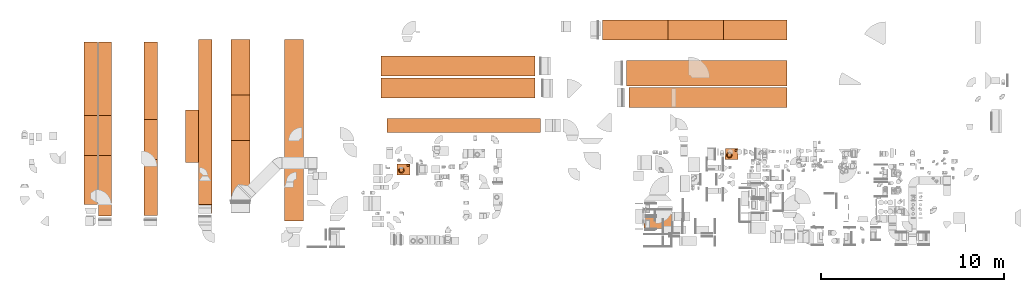
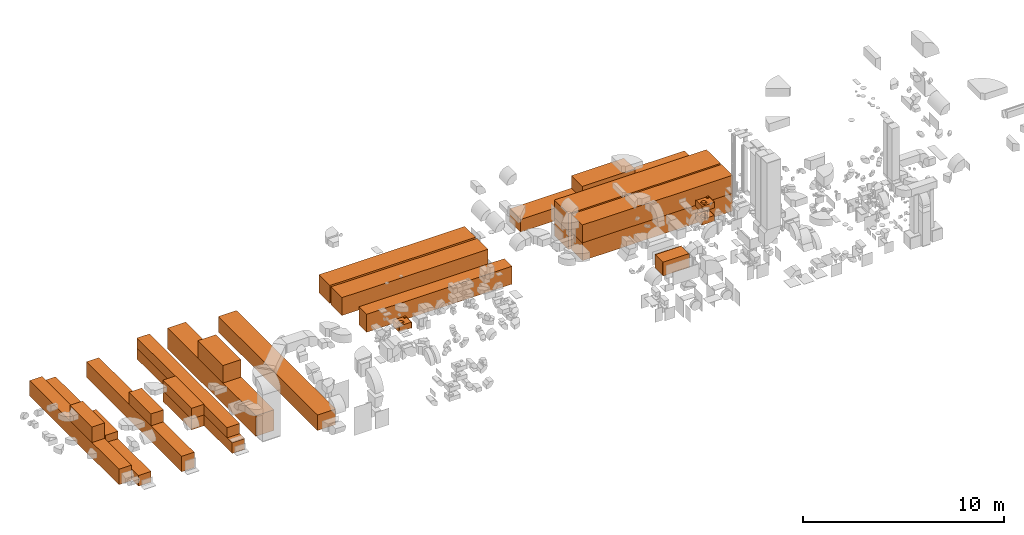
# One storey, part 58 of 59: 26 proxies.
"""IFC2X3 building model written with IfcOpenShell, lengths in millimetres."""

from ifc_helpers import new_model, entity, si_unit, converted_unit, derived_unit, direction, frame, origin, origin_2d_with_axis, place, context, subcontext, project, spatial, rectangle, extrude, faceted_brep, source, transform, mapped, material, material_list, type_object, type_shapes, element, save


model = new_model("IFC2X3")

# Units and contexts
model_context = context("Model", 3, precision=0.01, world=origin(), true_north=direction((6.12303176911189e-17, 1.0)))
body_context = subcontext(model_context, "Body", "Model", "MODEL_VIEW")
ifc_project = project(units=[si_unit("LENGTHUNIT", "METRE", prefix="MILLI"), si_unit("AREAUNIT", "SQUARE_METRE"), si_unit("VOLUMEUNIT", "CUBIC_METRE"), converted_unit("PLANEANGLEUNIT", "DEGREE", entity("IfcRatioMeasure", 0.0174532925199433), si_unit("PLANEANGLEUNIT", "RADIAN"), dimensions=[0, 0, 0, 0, 0, 0, 0]), si_unit("MASSUNIT", "GRAM", prefix="KILO"), derived_unit("MASSDENSITYUNIT", [(si_unit("MASSUNIT", "GRAM", prefix="KILO"), 1), (si_unit("LENGTHUNIT", "METRE"), -3)]), derived_unit("MOMENTOFINERTIAUNIT", [(si_unit("LENGTHUNIT", "METRE"), 4)]), si_unit("TIMEUNIT", "SECOND"), si_unit("FREQUENCYUNIT", "HERTZ"), si_unit("THERMODYNAMICTEMPERATUREUNIT", "DEGREE_CELSIUS"), derived_unit("THERMALTRANSMITTANCEUNIT", [(si_unit("MASSUNIT", "GRAM", prefix="KILO"), 1), (si_unit("THERMODYNAMICTEMPERATUREUNIT", "KELVIN"), -1), (si_unit("TIMEUNIT", "SECOND"), -3)]), derived_unit("VOLUMETRICFLOWRATEUNIT", [(si_unit("LENGTHUNIT", "METRE"), 3), (si_unit("TIMEUNIT", "SECOND"), -1)]), derived_unit("MASSFLOWRATEUNIT", [(si_unit("MASSUNIT", "GRAM", prefix="KILO"), 1), (si_unit("TIMEUNIT", "SECOND"), -1)]), derived_unit("ROTATIONALFREQUENCYUNIT", [(si_unit("TIMEUNIT", "SECOND"), -1)]), si_unit("ELECTRICCURRENTUNIT", "AMPERE"), si_unit("ELECTRICVOLTAGEUNIT", "VOLT"), si_unit("POWERUNIT", "WATT"), si_unit("FORCEUNIT", "NEWTON", prefix="KILO"), si_unit("ILLUMINANCEUNIT", "LUX"), si_unit("LUMINOUSFLUXUNIT", "LUMEN"), si_unit("LUMINOUSINTENSITYUNIT", "CANDELA"), derived_unit("USERDEFINED", [(si_unit("MASSUNIT", "GRAM", prefix="KILO"), -1), (si_unit("LENGTHUNIT", "METRE"), -2), (si_unit("TIMEUNIT", "SECOND"), 3), (si_unit("LUMINOUSFLUXUNIT", "LUMEN"), 1)]), derived_unit("LINEARVELOCITYUNIT", [(si_unit("LENGTHUNIT", "METRE"), 1), (si_unit("TIMEUNIT", "SECOND"), -1)]), si_unit("PRESSUREUNIT", "PASCAL"), derived_unit("USERDEFINED", [(si_unit("LENGTHUNIT", "METRE"), -2), (si_unit("MASSUNIT", "GRAM", prefix="KILO"), 1), (si_unit("TIMEUNIT", "SECOND"), -2)]), derived_unit("LINEARFORCEUNIT", [(si_unit("MASSUNIT", "GRAM", prefix="KILO"), 1), (si_unit("LENGTHUNIT", "METRE"), 1), (si_unit("TIMEUNIT", "SECOND"), -2), (si_unit("LENGTHUNIT", "METRE"), -1)]), derived_unit("PLANARFORCEUNIT", [(si_unit("MASSUNIT", "GRAM", prefix="KILO"), 1), (si_unit("LENGTHUNIT", "METRE"), 1), (si_unit("TIMEUNIT", "SECOND"), -2), (si_unit("LENGTHUNIT", "METRE"), -2)])], contexts=[model_context])

# Site, building, storey
site_placement = place(None, origin())
site = spatial("IfcSite", under=ifc_project, at=site_placement, CompositionType="ELEMENT")
building_placement = place(site_placement, origin())
building = spatial("IfcBuilding", under=site, at=building_placement, CompositionType="ELEMENT")
storey_placement = place(building_placement, frame((0.0, 0.0, 28200.0)))
storey = spatial("IfcBuildingStorey", under=building, at=storey_placement, CompositionType="ELEMENT", Elevation=28200.0)

# Proxies
ifc_material_1 = material()
building_element_proxy_type_1 = type_object("IfcBuildingElementProxyType", PredefinedType="NOTDEFINED", material=ifc_material_1)
shared_shape_1 = source(origin(), body_context, "Body", "SweptSolid", [
    extrude(rectangle(XDim=1090.0, YDim=8400.0, at=origin_2d_with_axis()), origin(), (0.0, 0.0, 1.0), 1090.0),
])
type_shapes(building_element_proxy_type_1, [shared_shape_1])
for number, where, z_axis, x_axis in (
    (1, (32267.57, 16479.61, 1240.0), (0.0, 0.0, 1.0), (1.51880240734974e-07, 1.0, 0.0)),
    (2, (32267.57, 17694.61, 1240.0), (0.0, 0.0, 1.0), (1.51880240734974e-07, 1.0, 0.0)),
):
    element("IfcBuildingElementProxy", number, at=place(storey_placement, frame(where, z_axis=z_axis, x_axis=x_axis)), inside=storey, type_object=building_element_proxy_type_1, material=ifc_material_1, context=body_context, shape_type="MappedRepresentation", body=[
        mapped(shared_shape_1, transform((0.0, 0.0, 0.0), scale=1.0)),
    ])
building_element_proxy_type_2 = type_object("IfcBuildingElementProxyType", PredefinedType="NOTDEFINED", material=ifc_material_1)
shared_shape_2 = source(origin(), body_context, "Body", "SweptSolid", [
    extrude(rectangle(XDim=770.0, YDim=8362.30252754303, at=origin_2d_with_axis()), origin(), (0.0, 0.0, 1.0), 1090.0),
])
type_shapes(building_element_proxy_type_2, [shared_shape_2])
proxy_1_placement = place(storey_placement, frame((32588.88, 14444.61, 1240.0), z_axis=(0.0, 0.0, 1.0), x_axis=(1.51880240734974e-07, 1.0, 0.0)))
element("IfcBuildingElementProxy", 3, at=proxy_1_placement, inside=storey, type_object=building_element_proxy_type_2, material=ifc_material_1, context=body_context, shape_type="MappedRepresentation", body=[
    mapped(shared_shape_2, transform((0.0, 0.0, 0.0), scale=1.0)),
])
building_element_proxy_type_3 = type_object("IfcBuildingElementProxyType", PredefinedType="NOTDEFINED", material=ifc_material_1)
shared_shape_3 = source(origin(), body_context, "Body", "SweptSolid", [
    extrude(rectangle(XDim=724.0, YDim=8898.98200064793, at=origin_2d_with_axis()), origin(), (0.0, 0.0, 1.0), 944.0),
])
type_shapes(building_element_proxy_type_3, [shared_shape_3])
proxy_2_placement = place(storey_placement, frame((12217.8, 14560.11, 150.0)))
element("IfcBuildingElementProxy", 4, at=proxy_2_placement, inside=storey, type_object=building_element_proxy_type_3, material=ifc_material_1, context=body_context, shape_type="MappedRepresentation", body=[
    mapped(shared_shape_3, transform((0.0, 0.0, 0.0), scale=1.0)),
])
building_element_proxy_type_4 = type_object("IfcBuildingElementProxyType", PredefinedType="NOTDEFINED", material=ifc_material_1)
shared_shape_4 = source(origin(), body_context, "Body", "SweptSolid", [
    extrude(rectangle(XDim=719.96467646969, YDim=2845.38357778285, at=origin_2d_with_axis()), origin(), (0.0, 0.0, 1.0), 654.0),
])
type_shapes(building_element_proxy_type_4, [shared_shape_4])
proxy_3_placement = place(storey_placement, frame((17738.36, 13852.3, 804.0)))
element("IfcBuildingElementProxy", 5, at=proxy_3_placement, inside=storey, type_object=building_element_proxy_type_4, material=ifc_material_1, context=body_context, shape_type="MappedRepresentation", body=[
    mapped(shared_shape_4, transform((0.0, 0.0, 0.0), scale=1.0)),
])
building_element_proxy_type_5 = type_object("IfcBuildingElementProxyType", PredefinedType="NOTDEFINED", material=ifc_material_1)
shared_shape_5 = source(origin(), body_context, "Body", "SweptSolid", [
    extrude(rectangle(XDim=723.999999999987, YDim=2845.90572539235, at=origin_2d_with_axis()), origin(), (0.0, 0.0, 1.0), 654.0),
])
type_shapes(building_element_proxy_type_5, [shared_shape_5])
proxy_4_placement = place(storey_placement, frame((17740.38, 13852.56, 150.0)))
element("IfcBuildingElementProxy", 6, at=proxy_4_placement, inside=storey, type_object=building_element_proxy_type_5, material=ifc_material_1, context=body_context, shape_type="MappedRepresentation", body=[
    mapped(shared_shape_5, transform((0.0, 0.0, 0.0), scale=1.0)),
])
building_element_proxy_type_6 = type_object("IfcBuildingElementProxyType", PredefinedType="NOTDEFINED", material=ifc_material_1)
shared_shape_6 = source(origin(), body_context, "Body", "SweptSolid", [
    extrude(rectangle(XDim=1044.00000000002, YDim=8799.99999999997, at=origin_2d_with_axis()), origin(), (0.0, 0.0, 1.0), 1264.0),
])
type_shapes(building_element_proxy_type_6, [shared_shape_6])
proxy_5_placement = place(storey_placement, frame((20389.38, 14726.65, 150.0)))
element("IfcBuildingElementProxy", 7, at=proxy_5_placement, inside=storey, type_object=building_element_proxy_type_6, material=ifc_material_1, context=body_context, shape_type="MappedRepresentation", body=[
    mapped(shared_shape_6, transform((0.0, 0.0, 0.0), scale=1.0)),
])
building_element_proxy_type_7 = type_object("IfcBuildingElementProxyType", PredefinedType="NOTDEFINED", material=ifc_material_1)
shared_shape_7 = source(origin(), body_context, "Body", "SweptSolid", [
    extrude(rectangle(XDim=724.0, YDim=2183.37539282111, at=origin_2d_with_axis()), origin(), (0.0, 0.0, 1.0), 944.0),
])
type_shapes(building_element_proxy_type_7, [shared_shape_7])
proxy_6_placement = place(storey_placement, frame((12217.8, 13881.29, 1094.0)))
element("IfcBuildingElementProxy", 8, at=proxy_6_placement, inside=storey, type_object=building_element_proxy_type_7, material=ifc_material_1, context=body_context, shape_type="MappedRepresentation", body=[
    mapped(shared_shape_7, transform((0.0, 0.0, 0.0), scale=1.0)),
])
building_element_proxy_type_8 = type_object("IfcBuildingElementProxyType", PredefinedType="NOTDEFINED", material=ifc_material_1)
shared_shape_8 = source(origin(), body_context, "Body", "SweptSolid", [
    extrude(rectangle(XDim=724.0, YDim=2183.37539282111, at=origin_2d_with_axis()), origin(), (0.0, 0.0, 1.0), 454.0),
])
type_shapes(building_element_proxy_type_8, [shared_shape_8])
proxy_7_placement = place(storey_placement, frame((12992.68, 13881.29, 804.0)))
element("IfcBuildingElementProxy", 9, at=proxy_7_placement, inside=storey, type_object=building_element_proxy_type_8, material=ifc_material_1, context=body_context, shape_type="MappedRepresentation", body=[
    mapped(shared_shape_8, transform((0.0, 0.0, 0.0), scale=1.0)),
])
building_element_proxy_type_9 = type_object("IfcBuildingElementProxyType", PredefinedType="NOTDEFINED", material=ifc_material_1)
shared_shape_9 = source(origin(), body_context, "Body", "SweptSolid", [
    extrude(rectangle(XDim=724.0, YDim=2183.37539282111, at=origin_2d_with_axis()), origin(), (0.0, 0.0, 1.0), 724.0),
])
type_shapes(building_element_proxy_type_9, [shared_shape_9])
proxy_8_placement = place(storey_placement, frame((15487.92, 13662.91, 1094.0)))
element("IfcBuildingElementProxy", 10, at=proxy_8_placement, inside=storey, type_object=building_element_proxy_type_9, material=ifc_material_1, context=body_context, shape_type="MappedRepresentation", body=[
    mapped(shared_shape_9, transform((0.0, 0.0, 0.0), scale=1.0)),
])
building_element_proxy_type_10 = type_object("IfcBuildingElementProxyType", PredefinedType="NOTDEFINED", material=ifc_material_1)
shared_shape_10 = source(origin(), body_context, "Body", "SweptSolid", [
    extrude(rectangle(XDim=724.0, YDim=9505.27999825652, at=origin_2d_with_axis()), origin(), (0.0, 0.0, 1.0), 654.0),
])
type_shapes(building_element_proxy_type_10, [shared_shape_10])
proxy_9_placement = place(storey_placement, frame((12992.68, 14256.96, 150.0)))
element("IfcBuildingElementProxy", 11, at=proxy_9_placement, inside=storey, type_object=building_element_proxy_type_10, material=ifc_material_1, context=body_context, shape_type="MappedRepresentation", body=[
    mapped(shared_shape_10, transform((0.0, 0.0, 0.0), scale=1.0)),
])
building_element_proxy_type_11 = type_object("IfcBuildingElementProxyType", PredefinedType="NOTDEFINED", material=ifc_material_1)
shared_shape_11 = source(origin(), body_context, "Body", "SweptSolid", [
    extrude(rectangle(XDim=724.0, YDim=9500.0, at=origin_2d_with_axis()), origin(), (0.0, 0.0, 1.0), 944.0),
])
type_shapes(building_element_proxy_type_11, [shared_shape_11])
proxy_10_placement = place(storey_placement, frame((15487.92, 14259.7, 150.0)))
element("IfcBuildingElementProxy", 12, at=proxy_10_placement, inside=storey, type_object=building_element_proxy_type_11, material=ifc_material_1, context=body_context, shape_type="MappedRepresentation", body=[
    mapped(shared_shape_11, transform((0.0, 0.0, 0.0), scale=1.0)),
])
building_element_proxy_type_12 = type_object("IfcBuildingElementProxyType", PredefinedType="NOTDEFINED", material=ifc_material_1)
shared_shape_12 = source(origin(), body_context, "Body", "SweptSolid", [
    extrude(rectangle(XDim=724.0, YDim=9499.95095119075, at=origin_2d_with_axis()), origin(), (0.0, 0.0, 1.0), 654.0),
])
type_shapes(building_element_proxy_type_12, [shared_shape_12])
proxy_11_placement = place(storey_placement, frame((18464.38, 14379.63, 150.0)))
element("IfcBuildingElementProxy", 13, at=proxy_11_placement, inside=storey, type_object=building_element_proxy_type_12, material=ifc_material_1, context=body_context, shape_type="MappedRepresentation", body=[
    mapped(shared_shape_12, transform((0.0, 0.0, 0.0), scale=1.0)),
])
building_element_proxy_type_13 = type_object("IfcBuildingElementProxyType", PredefinedType="NOTDEFINED", material=ifc_material_1)
shared_shape_13 = source(origin(), body_context, "Body", "SweptSolid", [
    extrude(rectangle(XDim=724.0, YDim=9000.00000000001, at=origin_2d_with_axis()), origin(), (0.0, 0.0, 1.0), 620.0),
])
type_shapes(building_element_proxy_type_13, [shared_shape_13])
proxy_12_placement = place(storey_placement, frame((18464.38, 14629.6, 804.0)))
element("IfcBuildingElementProxy", 14, at=proxy_12_placement, inside=storey, type_object=building_element_proxy_type_13, material=ifc_material_1, context=body_context, shape_type="MappedRepresentation", body=[
    mapped(shared_shape_13, transform((0.0, 0.0, 0.0), scale=1.0)),
])
building_element_proxy_type_14 = type_object("IfcBuildingElementProxyType", PredefinedType="NOTDEFINED", material=ifc_material_1)
shared_shape_14 = source(origin(), body_context, "Body", "SweptSolid", [
    extrude(rectangle(XDim=1037.62024276044, YDim=2500.0, at=origin_2d_with_axis()), origin(), (0.0, 0.0, 1.0), 1064.0),
])
type_shapes(building_element_proxy_type_14, [shared_shape_14])
proxy_13_placement = place(storey_placement, frame((20386.19, 14858.65, 1414.0)))
element("IfcBuildingElementProxy", 15, at=proxy_13_placement, inside=storey, type_object=building_element_proxy_type_14, material=ifc_material_1, context=body_context, shape_type="MappedRepresentation", body=[
    mapped(shared_shape_14, transform((0.0, 0.0, 0.0), scale=1.0)),
])
building_element_proxy_type_15 = type_object("IfcBuildingElementProxyType", PredefinedType="NOTDEFINED", material=ifc_material_1)
shared_shape_15 = source(origin(), body_context, "Body", "SweptSolid", [
    extrude(rectangle(XDim=1044.00000000001, YDim=9900.0, at=origin_2d_with_axis()), origin(), (0.0, 0.0, 1.0), 944.0),
])
type_shapes(building_element_proxy_type_15, [shared_shape_15])
proxy_14_placement = place(storey_placement, frame((23312.03, 14179.6, 150.0)))
element("IfcBuildingElementProxy", 16, at=proxy_14_placement, inside=storey, type_object=building_element_proxy_type_15, material=ifc_material_1, context=body_context, shape_type="MappedRepresentation", body=[
    mapped(shared_shape_15, transform((0.0, 0.0, 0.0), scale=1.0)),
])
ifc_material_2 = material()
ifc_material_list_1 = material_list([ifc_material_2, ifc_material_2, ifc_material_2])
building_element_proxy_type_16 = type_object("IfcBuildingElementProxyType", PredefinedType="NOTDEFINED", material=ifc_material_list_1)
shared_shape_16 = source(origin(), body_context, "Body", "SweptSolid", [
    extrude(rectangle(XDim=5.00000000000001, YDim=1540.0, at=origin_2d_with_axis()), frame((397.5, 0.0, -420.0), z_axis=(0.0, 0.0, 1.0), x_axis=(-1.0, 0.0, 0.0)), (0.0, 0.0, 1.0), 840.0),
    extrude(rectangle(XDim=5.00000000000001, YDim=1540.0, at=origin_2d_with_axis()), frame((-397.5, 0.0, -420.0), z_axis=(0.0, 0.0, 1.0), x_axis=(-1.0, 0.0, 0.0)), (0.0, 0.0, 1.0), 840.0),
    extrude(rectangle(XDim=800.0, YDim=1500.0, at=origin_2d_with_axis()), frame((0.0, 0.0, -400.0), z_axis=(0.0, 0.0, 1.0), x_axis=(-1.0, 0.0, 0.0)), (0.0, 0.0, 1.0), 799.999999999998),
])
type_shapes(building_element_proxy_type_16, [shared_shape_16])
proxy_15_placement = place(storey_placement, frame((43185.45, 9201.2, 3360.0), z_axis=(0.0, 0.0, 1.0), x_axis=(0.0, 1.0, 0.0)))
element("IfcBuildingElementProxy", 17, at=proxy_15_placement, inside=storey, type_object=building_element_proxy_type_16, material=ifc_material_list_1, context=body_context, shape_type="MappedRepresentation", body=[
    mapped(shared_shape_16, transform((0.0, 0.0, 0.0), scale=1.0)),
])
building_element_proxy_type_17 = type_object("IfcBuildingElementProxyType", PredefinedType="NOTDEFINED", material=ifc_material_1)
shared_shape_17 = source(origin(), body_context, "Body", "SweptSolid", [
    extrude(rectangle(XDim=1089.99999999995, YDim=10080.0, at=origin_2d_with_axis()), origin(), (0.0, 0.0, 1.0), 770.0),
])
type_shapes(building_element_proxy_type_17, [shared_shape_17])
proxy_16_placement = place(storey_placement, frame((45204.67, 19654.62, 150.0), z_axis=(0.0, 0.0, 1.0), x_axis=(0.0, -1.0, 0.0)))
element("IfcBuildingElementProxy", 18, at=proxy_16_placement, inside=storey, type_object=building_element_proxy_type_17, material=ifc_material_1, context=body_context, shape_type="MappedRepresentation", body=[
    mapped(shared_shape_17, transform((0.0, 0.0, 0.0), scale=1.0)),
])
building_element_proxy_type_18 = type_object("IfcBuildingElementProxyType", PredefinedType="NOTDEFINED", material=ifc_material_1)
shared_shape_18 = source(origin(), body_context, "Body", "SweptSolid", [
    extrude(rectangle(XDim=1089.99999999995, YDim=3030.0, at=origin_2d_with_axis()), origin(), (0.0, 0.0, 1.0), 770.0),
])
type_shapes(building_element_proxy_type_18, [shared_shape_18])
proxy_17_placement = place(storey_placement, frame((45253.22, 19654.62, 920.0), z_axis=(0.0, 0.0, 1.0), x_axis=(0.0, -1.0, 0.0)))
element("IfcBuildingElementProxy", 19, at=proxy_17_placement, inside=storey, type_object=building_element_proxy_type_18, material=ifc_material_1, context=body_context, shape_type="MappedRepresentation", body=[
    mapped(shared_shape_18, transform((0.0, 0.0, 0.0), scale=1.0)),
])
building_element_proxy_type_19 = type_object("IfcBuildingElementProxyType", PredefinedType="NOTDEFINED", material=ifc_material_1)
shared_shape_19 = source(origin(), body_context, "Body", "SweptSolid", [
    extrude(rectangle(XDim=1389.99999999993, YDim=8760.00000000002, at=origin_2d_with_axis()), origin(), (0.0, 0.0, 1.0), 1090.0),
])
type_shapes(building_element_proxy_type_19, [shared_shape_19])
for number, where, z_axis, x_axis in (
    (20, (45863.7, 17294.64, 150.0), (0.0, 0.0, 1.0), (0.0, -1.0, 0.0)),
    (21, (45863.7, 17294.64, 1240.0), (0.0, 0.0, 1.0), (0.0, -1.0, 0.0)),
):
    element("IfcBuildingElementProxy", number, at=place(storey_placement, frame(where, z_axis=z_axis, x_axis=x_axis)), inside=storey, type_object=building_element_proxy_type_19, material=ifc_material_1, context=body_context, shape_type="MappedRepresentation", body=[
        mapped(shared_shape_19, transform((0.0, 0.0, 0.0), scale=1.0)),
    ])
building_element_proxy_type_20 = type_object("IfcBuildingElementProxyType", PredefinedType="NOTDEFINED", material=ifc_material_1)
shared_shape_20 = source(origin(), body_context, "Body", "SweptSolid", [
    extrude(rectangle(XDim=1089.99999999996, YDim=8640.00000000001, at=origin_2d_with_axis()), origin(), (0.0, 0.0, 1.0), 1090.0),
])
type_shapes(building_element_proxy_type_20, [shared_shape_20])
for number, where, z_axis, x_axis in (
    (22, (45923.7, 15954.64, 150.0), (0.0, 0.0, 1.0), (0.0, -1.0, 0.0)),
    (23, (45923.7, 15954.64, 1240.0), (0.0, 0.0, 1.0), (0.0, -1.0, 0.0)),
):
    element("IfcBuildingElementProxy", number, at=place(storey_placement, frame(where, z_axis=z_axis, x_axis=x_axis)), inside=storey, type_object=building_element_proxy_type_20, material=ifc_material_1, context=body_context, shape_type="MappedRepresentation", body=[
        mapped(shared_shape_20, transform((0.0, 0.0, 0.0), scale=1.0)),
    ])
ifc_material_3 = material()
ifc_material_4 = material()
ifc_material_list_2 = material_list([ifc_material_3, ifc_material_4])
ifc_material_5 = material()
ifc_material_list_3 = material_list([ifc_material_4, ifc_material_5, ifc_material_3])
building_element_proxy_type_21 = type_object("IfcBuildingElementProxyType", PredefinedType="NOTDEFINED", material=ifc_material_list_3)
shared_shape_21 = source(origin(), body_context, "Body", "Brep", [
    faceted_brep([(-188.5, -182.29, 203.93), (-188.5, -180.29, 201.93), (-188.5, -178.29, 203.93), (-188.5, -180.29, 205.93), (-198.5, -175.29, 195.27), (-198.5, -185.29, 195.27), (-198.5, -190.29, 203.93), (-198.5, -185.29, 212.59), (-198.5, -175.29, 212.59), (-198.5, -170.29, 203.93)], [[[0, 1, 2, 3]], [[4, 5, 6, 7, 8, 9]], [[2, 4, 9]], [[4, 2, 1]], [[1, 0, 5]], [[6, 5, 0]], [[1, 5, 4]], [[0, 7, 6]], [[7, 0, 3]], [[3, 2, 8]], [[9, 8, 2]], [[3, 8, 7]]]),
    faceted_brep([(-188.5, -226.95, 203.93), (-188.5, -228.95, 205.93), (-188.5, -230.95, 203.93), (-188.5, -228.95, 201.93), (-198.5, -223.95, 212.59), (-198.5, -218.95, 203.93), (-198.5, -223.95, 195.27), (-198.5, -233.95, 195.27), (-198.5, -238.95, 203.93), (-198.5, -233.95, 212.59)], [[[0, 1, 2, 3]], [[4, 5, 6, 7, 8, 9]], [[0, 6, 5]], [[6, 0, 3]], [[3, 2, 7]], [[8, 7, 2]], [[3, 7, 6]], [[2, 9, 8]], [[9, 2, 1]], [[1, 0, 4]], [[5, 4, 0]], [[1, 4, 9]]]),
    faceted_brep([(-318.5, -182.29, 203.93), (-318.5, -180.29, 205.93), (-318.5, -178.29, 203.93), (-318.5, -180.29, 201.93), (-308.5, -185.29, 212.59), (-308.5, -190.29, 203.93), (-308.5, -185.29, 195.27), (-308.5, -175.29, 195.27), (-308.5, -170.29, 203.93), (-308.5, -175.29, 212.59)], [[[0, 1, 2, 3]], [[4, 5, 6, 7, 8, 9]], [[0, 6, 5]], [[6, 0, 3]], [[3, 2, 7]], [[8, 7, 2]], [[3, 7, 6]], [[2, 9, 8]], [[9, 2, 1]], [[1, 0, 4]], [[5, 4, 0]], [[1, 4, 9]]]),
    faceted_brep([(-318.5, -226.95, 203.93), (-318.5, -228.95, 201.93), (-318.5, -230.95, 203.93), (-318.5, -228.95, 205.93), (-308.5, -233.95, 195.27), (-308.5, -223.95, 195.27), (-308.5, -218.95, 203.93), (-308.5, -223.95, 212.59), (-308.5, -233.95, 212.59), (-308.5, -238.95, 203.93)], [[[0, 1, 2, 3]], [[4, 5, 6, 7, 8, 9]], [[2, 4, 9]], [[4, 2, 1]], [[1, 0, 5]], [[6, 5, 0]], [[1, 5, 4]], [[0, 7, 6]], [[7, 0, 3]], [[3, 2, 8]], [[9, 8, 2]], [[3, 8, 7]]]),
    faceted_brep([(-231.17, -140.0, 203.93), (-229.17, -140.0, 205.93), (-227.17, -140.0, 203.93), (-229.17, -140.0, 201.93), (-234.17, -150.0, 212.59), (-239.17, -150.0, 203.93), (-234.17, -150.0, 195.27), (-224.17, -150.0, 195.27), (-219.17, -150.0, 203.93), (-224.17, -150.0, 212.59)], [[[0, 1, 2, 3]], [[4, 5, 6, 7, 8, 9]], [[0, 6, 5]], [[6, 0, 3]], [[3, 2, 7]], [[8, 7, 2]], [[3, 7, 6]], [[2, 9, 8]], [[9, 2, 1]], [[1, 0, 4]], [[5, 4, 0]], [[1, 4, 9]]]),
    faceted_brep([(-275.83, -140.0, 203.93), (-277.83, -140.0, 201.93), (-279.83, -140.0, 203.93), (-277.83, -140.0, 205.93), (-272.83, -150.0, 195.27), (-267.83, -150.0, 203.93), (-272.83, -150.0, 212.59), (-282.83, -150.0, 212.59), (-287.83, -150.0, 203.93), (-282.83, -150.0, 195.27)], [[[0, 1, 2, 3]], [[4, 5, 6, 7, 8, 9]], [[2, 9, 8]], [[9, 2, 1]], [[1, 0, 4]], [[5, 4, 0]], [[1, 4, 9]], [[0, 6, 5]], [[6, 0, 3]], [[3, 2, 7]], [[8, 7, 2]], [[3, 7, 6]]]),
    faceted_brep([(-231.17, -270.0, 203.93), (-229.17, -270.0, 201.93), (-227.17, -270.0, 203.93), (-229.17, -270.0, 205.93), (-234.17, -260.0, 195.27), (-239.17, -260.0, 203.93), (-234.17, -260.0, 212.59), (-224.17, -260.0, 212.59), (-219.17, -260.0, 203.93), (-224.17, -260.0, 195.27)], [[[0, 1, 2, 3]], [[4, 5, 6, 7, 8, 9]], [[2, 9, 8]], [[9, 2, 1]], [[1, 0, 4]], [[5, 4, 0]], [[1, 4, 9]], [[0, 6, 5]], [[6, 0, 3]], [[3, 2, 7]], [[8, 7, 2]], [[3, 7, 6]]]),
    faceted_brep([(-275.83, -270.0, 203.93), (-277.83, -270.0, 205.93), (-279.83, -270.0, 203.93), (-277.83, -270.0, 201.93), (-282.83, -260.0, 212.59), (-272.83, -260.0, 212.59), (-267.83, -260.0, 203.93), (-272.83, -260.0, 195.27), (-282.83, -260.0, 195.27), (-287.83, -260.0, 203.93)], [[[0, 1, 2, 3]], [[4, 5, 6, 7, 8, 9]], [[0, 7, 6]], [[7, 0, 3]], [[3, 2, 8]], [[9, 8, 2]], [[3, 8, 7]], [[2, 4, 9]], [[4, 2, 1]], [[1, 0, 5]], [[6, 5, 0]], [[1, 5, 4]]]),
    faceted_brep([(-213.5, -150.0, 235.0), (-293.5, -150.0, 235.0), (-297.38, -150.51, 235.0), (-301.0, -152.01, 235.0), (-304.11, -154.39, 235.0), (-306.49, -157.5, 235.0), (-307.99, -161.12, 235.0), (-308.5, -165.0, 235.0), (-308.5, -245.0, 235.0), (-307.99, -248.88, 235.0), (-306.49, -252.5, 235.0), (-304.11, -255.61, 235.0), (-301.0, -257.99, 235.0), (-297.38, -259.49, 235.0), (-293.5, -260.0, 235.0), (-213.5, -260.0, 235.0), (-209.62, -259.49, 235.0), (-206.0, -257.99, 235.0), (-202.89, -255.61, 235.0), (-200.51, -252.5, 235.0), (-199.01, -248.88, 235.0), (-198.5, -245.0, 235.0), (-198.5, -165.0, 235.0), (-199.01, -161.12, 235.0), (-200.51, -157.5, 235.0), (-202.89, -154.39, 235.0), (-206.0, -152.01, 235.0), (-209.62, -150.51, 235.0), (-297.38, -150.51, 175.0), (-293.5, -150.0, 175.0), (-213.5, -150.0, 175.0), (-209.62, -150.51, 175.0), (-206.0, -152.01, 175.0), (-202.89, -154.39, 175.0), (-200.51, -157.5, 175.0), (-199.01, -161.12, 175.0), (-198.5, -165.0, 175.0), (-198.5, -245.0, 175.0), (-199.01, -248.88, 175.0), (-200.51, -252.5, 175.0), (-202.89, -255.61, 175.0), (-206.0, -257.99, 175.0), (-209.62, -259.49, 175.0), (-213.5, -260.0, 175.0), (-293.5, -260.0, 175.0), (-297.38, -259.49, 175.0), (-301.0, -257.99, 175.0), (-304.11, -255.61, 175.0), (-306.49, -252.5, 175.0), (-307.99, -248.88, 175.0), (-308.5, -245.0, 175.0), (-308.5, -165.0, 175.0), (-307.99, -161.12, 175.0), (-306.49, -157.5, 175.0), (-304.11, -154.39, 175.0), (-301.0, -152.01, 175.0)], [[[0, 1, 2, 3, 4, 5, 6, 7, 8, 9, 10, 11, 12, 13, 14, 15, 16, 17, 18, 19, 20, 21, 22, 23, 24, 25, 26, 27]], [[28, 29, 30, 31, 32, 33, 34, 35, 36, 37, 38, 39, 40, 41, 42, 43, 44, 45, 46, 47, 48, 49, 50, 51, 52, 53, 54, 55]], [[1, 0, 30, 29]], [[2, 28, 55, 3]], [[3, 55, 54, 4]], [[29, 28, 2, 1]], [[5, 53, 52, 6]], [[6, 52, 51, 7]], [[4, 54, 53, 5]], [[8, 7, 51, 50]], [[9, 49, 48, 10]], [[10, 48, 47, 11]], [[50, 49, 9, 8]], [[12, 46, 45, 13]], [[13, 45, 44, 14]], [[11, 47, 46, 12]], [[15, 14, 44, 43]], [[16, 42, 41, 17]], [[17, 41, 40, 18]], [[43, 42, 16, 15]], [[19, 39, 38, 20]], [[20, 38, 37, 21]], [[18, 40, 39, 19]], [[22, 21, 37, 36]], [[23, 35, 34, 24]], [[24, 34, 33, 25]], [[36, 35, 23, 22]], [[26, 32, 31, 27]], [[27, 31, 30, 0]], [[25, 33, 32, 26]]]),
    faceted_brep([(363.5, -320.0, 195.0), (363.5, -320.0, -195.0), (363.5, 320.0, -195.0), (363.5, 320.0, 195.0), (358.5, -320.0, 195.0), (358.5, 320.0, 195.0), (358.5, 320.0, -195.0), (358.5, -320.0, -195.0)], [[[0, 1, 2, 3]], [[4, 5, 6, 7]], [[1, 0, 4, 7]], [[2, 1, 7, 6]], [[3, 2, 6, 5]], [[0, 3, 5, 4]]]),
    faceted_brep([(-358.5, -320.0, 195.0), (-358.5, -320.0, -195.0), (-358.5, 320.0, -195.0), (-358.5, 320.0, 195.0), (-363.5, -320.0, 195.0), (-363.5, 320.0, 195.0), (-363.5, 320.0, -195.0), (-363.5, -320.0, -195.0)], [[[0, 1, 2, 3]], [[4, 5, 6, 7]], [[1, 0, 4, 7]], [[2, 1, 7, 6]], [[3, 2, 6, 5]], [[0, 3, 5, 4]]]),
    faceted_brep([(358.5, -300.0, 175.0), (358.5, -300.0, -175.0), (358.5, 300.0, -175.0), (358.5, 300.0, 175.0), (-358.5, -300.0, 175.0), (-358.5, 300.0, 175.0), (-358.5, 300.0, -175.0), (-358.5, -300.0, -175.0)], [[[0, 1, 2, 3]], [[4, 5, 6, 7]], [[1, 0, 4, 7]], [[2, 1, 7, 6]], [[3, 2, 6, 5]], [[0, 3, 5, 4]]]),
    faceted_brep([(223.22, 53.64, 223.0), (217.84, 87.63, 223.0), (202.22, 118.29, 223.0), (177.88, 142.63, 223.0), (147.22, 158.25, 223.0), (113.22, 163.64, 223.0), (79.23, 158.25, 223.0), (48.57, 142.63, 223.0), (24.23, 118.29, 223.0), (8.61, 87.63, 223.0), (3.22, 53.64, 223.0), (8.61, 19.65, 223.0), (24.23, -11.02, 223.0), (48.57, -35.35, 223.0), (79.23, -50.98, 223.0), (113.22, -56.36, 223.0), (147.22, -50.98, 223.0), (177.88, -35.35, 223.0), (202.22, -11.02, 223.0), (217.84, 19.65, 223.0), (273.22, 53.64, 175.0), (267.77, 12.23, 175.0), (251.79, -26.36, 175.0), (226.36, -59.5, 175.0), (193.22, -84.93, 175.0), (154.64, -100.91, 175.0), (113.22, -106.36, 175.0), (71.81, -100.91, 175.0), (33.22, -84.93, 175.0), (0.09, -59.5, 175.0), (-25.34, -26.36, 175.0), (-41.32, 12.23, 175.0), (-46.78, 53.64, 175.0), (-41.32, 95.05, 175.0), (-25.34, 133.64, 175.0), (0.09, 166.77, 175.0), (33.22, 192.2, 175.0), (71.81, 208.19, 175.0), (113.22, 213.64, 175.0), (154.64, 208.19, 175.0), (193.22, 192.2, 175.0), (226.36, 166.77, 175.0), (251.79, 133.64, 175.0), (267.77, 95.05, 175.0)], [[[0, 1, 2, 3, 4, 5, 6, 7, 8, 9, 10, 11, 12, 13, 14, 15, 16, 17, 18, 19]], [[20, 21, 22, 23, 24, 25, 26, 27, 28, 29, 30, 31, 32, 33, 34, 35, 36, 37, 38, 39, 40, 41, 42, 43]], [[14, 13, 28]], [[15, 14, 27]], [[11, 10, 31]], [[12, 11, 30]], [[13, 12, 29]], [[14, 28, 27]], [[27, 26, 15]], [[13, 29, 28]], [[12, 30, 29]], [[30, 11, 31]], [[10, 32, 31]], [[32, 10, 33]], [[33, 10, 9]], [[8, 34, 9]], [[36, 7, 6]], [[35, 8, 7]], [[37, 6, 5]], [[9, 34, 33]], [[8, 35, 34]], [[36, 35, 7]], [[6, 37, 36]], [[5, 38, 37]], [[4, 3, 40]], [[5, 4, 39]], [[1, 0, 43]], [[2, 1, 42]], [[3, 2, 41]], [[4, 40, 39]], [[39, 38, 5]], [[3, 41, 40]], [[2, 42, 41]], [[42, 1, 43]], [[0, 20, 43]], [[20, 0, 21]], [[21, 0, 19]], [[18, 22, 19]], [[24, 17, 16]], [[23, 18, 17]], [[25, 16, 15]], [[19, 22, 21]], [[18, 23, 22]], [[24, 23, 17]], [[16, 25, 24]], [[15, 26, 25]]]),
])
type_shapes(building_element_proxy_type_21, [shared_shape_21])
proxy_18_placement = place(storey_placement, frame((29294.71, 12045.06, 2650.0), z_axis=(0.0, 0.0, 1.0), x_axis=(-1.0, 0.0, 0.0)))
element("IfcBuildingElementProxy", 24, at=proxy_18_placement, inside=storey, type_object=building_element_proxy_type_21, material=ifc_material_list_2, context=body_context, shape_type="MappedRepresentation", body=[
    mapped(shared_shape_21, transform((0.0, 0.0, 0.0), scale=1.0)),
])
ifc_material_list_4 = material_list([ifc_material_5, ifc_material_4, ifc_material_3])
building_element_proxy_type_22 = type_object("IfcBuildingElementProxyType", PredefinedType="NOTDEFINED", material=ifc_material_list_4)
type_shapes(building_element_proxy_type_22, [shared_shape_21])
for number, where, z_axis, x_axis in (
    (25, (47207.98, 12874.75, 2370.0), (0.0, 0.0, 1.0), (-1.0, 0.0, 0.0)),
    (26, (47207.98, 12874.75, 3170.0), (0.0, 0.0, 1.0), (-1.0, 0.0, 0.0)),
):
    element("IfcBuildingElementProxy", number, at=place(storey_placement, frame(where, z_axis=z_axis, x_axis=x_axis)), inside=storey, type_object=building_element_proxy_type_22, material=ifc_material_list_2, context=body_context, shape_type="MappedRepresentation", body=[
        mapped(shared_shape_21, transform((0.0, 0.0, 0.0), scale=1.0)),
    ])

save(model, "model.ifc")
